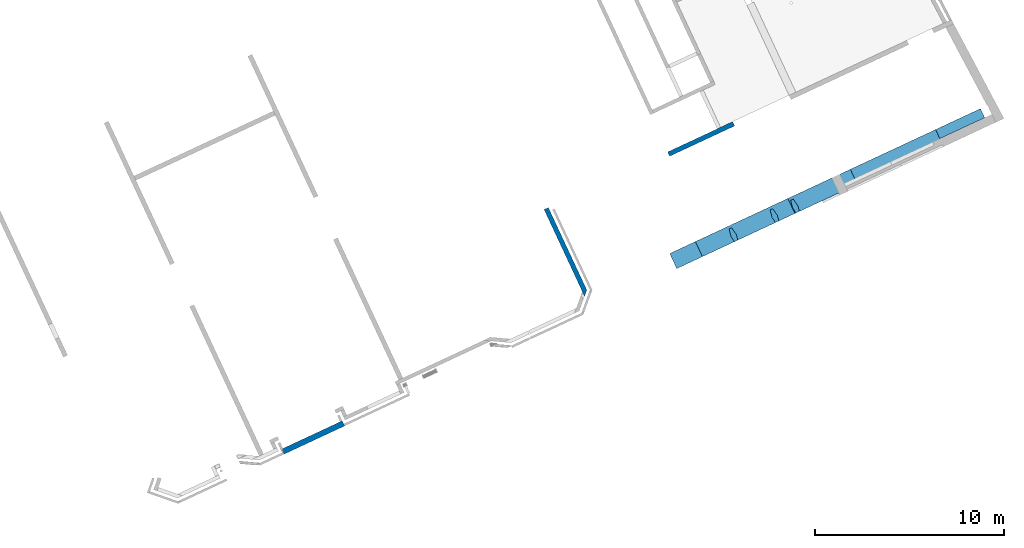
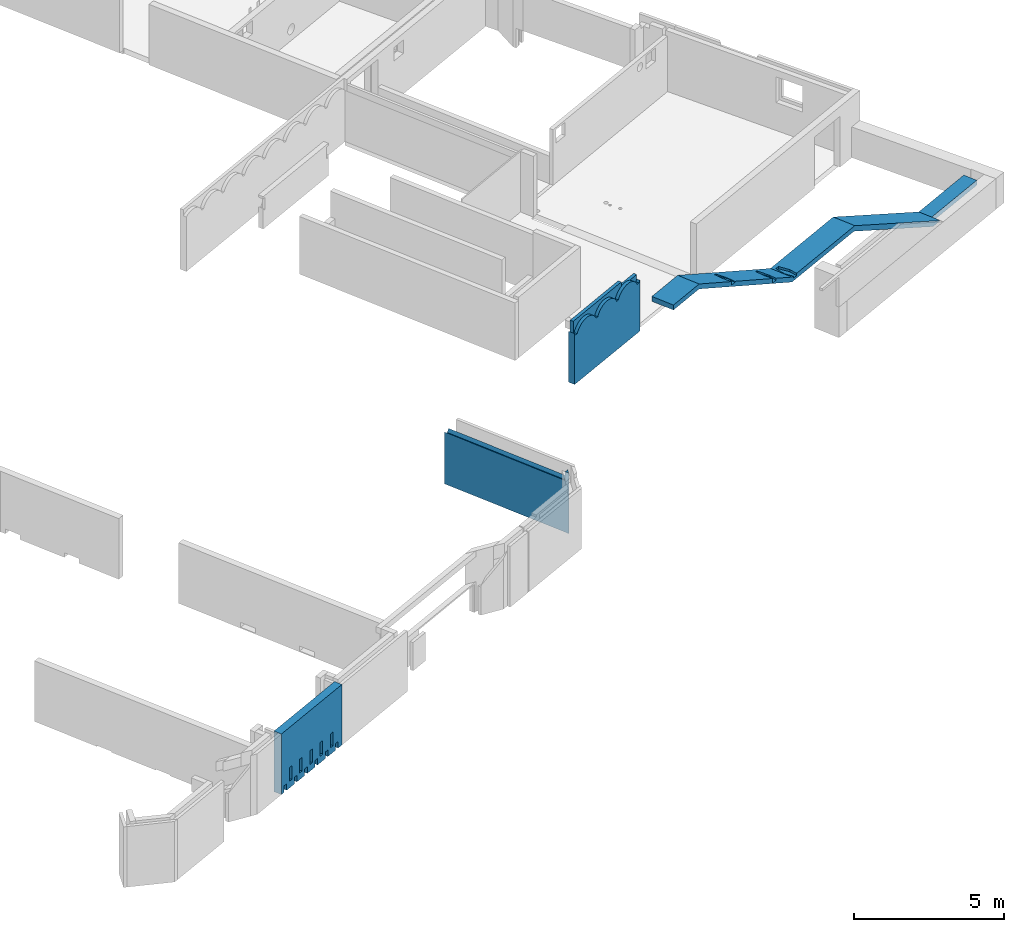
# One storey, part 6 of 13: 3 walls, 1 beam.
"""IFC2X3 building model written with IfcOpenShell, lengths in metres."""

from ifc_helpers import new_model, entity, si_unit, converted_unit, derived_unit, direction, frame, origin, place, context, subcontext, project, spatial, faceted_brep, material, layer, layer_set, type_object, element, save


model = new_model("IFC2X3")

# Units and contexts
model_context = context("Model", 3, precision=1e-05, world=origin(), true_north=direction((6.12303176911189e-17, 1.0)))
body_context = subcontext(model_context, "Body", "Model", "MODEL_VIEW")
ifc_project = project(units=[si_unit("LENGTHUNIT", "METRE"), si_unit("AREAUNIT", "SQUARE_METRE"), si_unit("VOLUMEUNIT", "CUBIC_METRE"), converted_unit("PLANEANGLEUNIT", "DEGREE", entity("IfcRatioMeasure", 0.0174532925199433), si_unit("PLANEANGLEUNIT", "RADIAN"), dimensions=[0, 0, 0, 0, 0, 0, 0]), si_unit("MASSUNIT", "GRAM", prefix="KILO"), derived_unit("MASSDENSITYUNIT", [(si_unit("MASSUNIT", "GRAM", prefix="KILO"), 1), (si_unit("LENGTHUNIT", "METRE"), -3)]), si_unit("TIMEUNIT", "SECOND"), si_unit("FREQUENCYUNIT", "HERTZ"), si_unit("THERMODYNAMICTEMPERATUREUNIT", "DEGREE_CELSIUS"), derived_unit("THERMALTRANSMITTANCEUNIT", [(si_unit("MASSUNIT", "GRAM", prefix="KILO"), 1), (si_unit("THERMODYNAMICTEMPERATUREUNIT", "KELVIN"), -1), (si_unit("TIMEUNIT", "SECOND"), -3)]), derived_unit("VOLUMETRICFLOWRATEUNIT", [(si_unit("LENGTHUNIT", "METRE"), 3), (si_unit("TIMEUNIT", "SECOND"), -1)]), si_unit("ELECTRICCURRENTUNIT", "AMPERE"), si_unit("ELECTRICVOLTAGEUNIT", "VOLT"), si_unit("POWERUNIT", "WATT"), si_unit("FORCEUNIT", "NEWTON", prefix="KILO"), si_unit("ILLUMINANCEUNIT", "LUX"), si_unit("LUMINOUSFLUXUNIT", "LUMEN"), si_unit("LUMINOUSINTENSITYUNIT", "CANDELA"), derived_unit("USERDEFINED", [(si_unit("MASSUNIT", "GRAM", prefix="KILO"), -1), (si_unit("LENGTHUNIT", "METRE"), -2), (si_unit("TIMEUNIT", "SECOND"), 3), (si_unit("LUMINOUSFLUXUNIT", "LUMEN"), 1)]), derived_unit("LINEARVELOCITYUNIT", [(si_unit("LENGTHUNIT", "METRE"), 1), (si_unit("TIMEUNIT", "SECOND"), -1)]), si_unit("PRESSUREUNIT", "PASCAL"), derived_unit("USERDEFINED", [(si_unit("LENGTHUNIT", "METRE"), -2), (si_unit("MASSUNIT", "GRAM", prefix="KILO"), 1), (si_unit("TIMEUNIT", "SECOND"), -2)])], contexts=[model_context])

# Site, building, storey
site_placement = place(None, frame((5.36960000000003, 43.3158000000006, 0.0), z_axis=(0.0, 0.0, 1.0), x_axis=(-0.422618261740703, 0.906307787036648, 0.0)))
site = spatial("IfcSite", under=ifc_project, at=site_placement, CompositionType="ELEMENT")
building_placement = place(site_placement, origin())
building = spatial("IfcBuilding", under=site, at=building_placement, CompositionType="ELEMENT")
storey_placement = place(building_placement, frame((0.0, 0.0, 2.56)))
storey = spatial("IfcBuildingStorey", under=building, at=storey_placement, CompositionType="ELEMENT", Elevation=2.56)

# Beam
ifc_material_1 = material(Name="BA")
beam_type = type_object("IfcBeamType", Name="SP_26_02_2:variable", PredefinedType="BEAM")
beam_placement = place(storey_placement, frame((0.120660848232912, 0.93585733205605, 1.04999999999999)))
element("IfcBeam", 1, at=beam_placement, inside=storey, type_object=beam_type, material=ifc_material_1, Name="SP_26_02_2:variable", ObjectType="SP_26_02_2:variable", context=body_context, shape_type="Brep", body=[
    faceted_brep([(0.880000000004672, 11.2638348482751, 2.85000000000001), (0.880000000004631, 7.60812275855246, 2.84999999999992), (0.880000000004576, 2.62419762538485, 0.200000000000014), (0.880000000004546, 0.0, 0.200000000000014), (0.880000000004546, 0.0, 0.0), (0.880000000004576, 2.67406322595346, 0.0), (0.880000000004632, 7.6579883591211, 2.64999999999992), (0.880000000004672, 11.2696234098998, 2.65000000000001), (0.880000000004732, 16.6754439072589, 5.47000000000002), (0.880000000004749, 18.1716685169687, 5.47000000000002), (0.880000000004749, 18.1716685169687, 5.67000000000001), (0.880000000004732, 16.6696553456341, 5.67000000000001), (0.0, 11.2638348482751, 2.85000000000001), (0.0, 11.192843488021, 2.85000000000001), (0.305008497369673, 11.2466685169686, 2.85000000000001), (0.730008497369677, 11.1716685169687, 2.85000000000001), (0.730008497369686, 11.0216685169687, 2.85), (0.305008497369691, 10.9466685169686, 2.85), (0.0, 11.0004935459162, 2.85), (0.0, 9.67058952069909, 2.84999999999997), (0.0, 7.60812275855247, 2.84999999999992), (0.0865825330115125, 7.60812275855247, 2.84999999999992), (0.52343446172795, 7.60812275855247, 2.84999999999992), (0.730000000004716, 2.62419762538485, 0.200000000000014), (0.350000000004517, 2.62419762538486, 0.200000000000014), (0.350000000004492, 0.0, 0.200000000000014), (0.350000000004492, 0.0, 0.0), (0.350000000004517, 2.67406322595347, 0.0), (0.350000000004512, 7.65798835912111, 2.64999999999992), (0.150000000004523, 7.65798835912111, 2.64999999999992), (0.0, 7.65798835912111, 2.64999999999992), (0.0, 11.2696234098998, 2.65000000000001), (0.150000000000136, 11.2696234098998, 2.65000000000001), (0.350000000000125, 11.2696234098998, 2.65000000000001), (0.350000000000216, 18.1716685169687, 5.67000000000001), (0.150000000000227, 18.1716685169687, 5.67000000000001), (0.0, 18.1716685169687, 5.67000000000001), (0.0, 16.6696553456342, 5.67000000000001), (0.350000000000216, 18.1716685169687, 5.47000000000002), (0.150000000000227, 18.1716685169687, 5.47000000000002), (0.0, 18.1716685169687, 5.47000000000002), (0.350000000000196, 16.6754439072589, 5.47000000000002), (0.150000000000207, 16.6754439072589, 5.47000000000002), (0.0, 16.6754439072589, 5.47000000000002), (0.350000000004521, 3.05020851902277, 0.200000000000014), (0.150000000004479, 3.05020851902277, 0.200000000000014), (0.0, 3.05020851902277, 0.200000000000014), (0.0, 7.48872297724012, 2.56000000000001), (0.0, 7.59284348802103, 2.61536185761163), (0.0, 2.62419762538486, 0.200000000000014), (0.0, 15.9853391629152, 5.11000000000001), (0.0, 15.9928434880211, 5.11391470578963), (0.261369741428162, 12.4389675600378, 3.26000000000001), (0.348647253311243, 12.4389675600378, 3.26000000000001), (0.305008497369684, 12.4466685169686, 3.26401728073577), (0.0, 14.7928434880211, 4.69094243768277), (0.305008497369708, 14.8466685169687, 4.71902079909088), (0.730008497369711, 14.7716685169687, 4.6798963035396), (0.730008497369721, 14.6216685169687, 4.60164731243702), (0.305008497369727, 14.5466685169686, 4.56252281688571), (0.0, 14.6004935459162, 4.5906011782938), (0.0, 12.3928434880211, 3.43895858004146), (0.305008497369684, 12.4466685169686, 3.46703694144957), (0.730008497369689, 12.3716685169687, 3.4279124458983), (0.730008497369698, 12.2216685169687, 3.34966345479572), (0.305008497369703, 12.1466685169686, 3.31053895924441), (0.0, 12.2004935459162, 3.3386173206525), (0.730008497369677, 11.1716685169687, 2.76000000000001), (0.350000000000124, 11.2387288400339, 2.76000000000001), (0.305008497369673, 11.2466685169686, 2.76000000000001), (0.150000000000136, 11.2193140762564, 2.76000000000001), (0.0, 11.192843488021, 2.76000000000001), (0.0, 11.0004935459162, 2.76000000000001), (0.150000000000133, 10.9740229576809, 2.76000000000001), (0.305008497369691, 10.9466685169686, 2.76000000000001), (0.350000000000121, 10.9546081939034, 2.76000000000001), (0.730008497369686, 11.0216685169687, 2.76000000000001), (0.730008497369712, 14.7716685169687, 4.54000000000001), (0.350000000000172, 14.8387288400339, 4.54000000000001), (0.305008497369707, 14.8466685169687, 4.54000000000001), (0.150000000000183, 14.8193140762564, 4.54000000000001), (0.0, 14.7928434880211, 4.54000000000001), (0.0, 14.6004935459162, 4.54000000000001), (0.15000000000018, 14.5740229576809, 4.54000000000001), (0.305008497369726, 14.5466685169687, 4.54000000000001), (0.350000000000168, 14.5546081939034, 4.54000000000001), (0.730008497369721, 14.6216685169687, 4.54000000000001), (0.730008497369698, 12.2216685169687, 3.26000000000001), (0.730008497369688, 12.3716685169687, 3.26000000000001), (0.35000000000014, 12.4387288400339, 3.26000000000001), (0.150000000000151, 12.4193140762564, 3.26000000000001), (0.0, 12.3928434880211, 3.26000000000001), (0.0, 12.2004935459162, 3.26000000000001), (0.150000000000148, 12.1740229576809, 3.26000000000001), (0.305008497369703, 12.1466685169686, 3.26000000000001), (0.350000000000137, 12.1546081939034, 3.26000000000001)], [[[0, 1, 2, 3, 4, 5, 6, 7, 8, 9, 10, 11]], [[1, 0, 12, 13, 14, 15, 16, 17, 18, 19, 20, 21, 22]], [[3, 2, 23, 24, 25]], [[4, 3, 25, 26]], [[5, 4, 26, 27]], [[7, 6, 28, 29, 30, 31, 32, 33]], [[11, 10, 34, 35, 36, 37]], [[10, 9, 38, 39, 40, 36, 35, 34]], [[9, 8, 41, 42, 43, 40, 39, 38]], [[6, 5, 27, 44, 45, 46, 47, 48, 30, 29, 28]], [[2, 1, 22, 21, 20, 49, 24, 23]], [[8, 7, 33, 32, 31, 50, 51, 43, 42, 41], [52, 53, 54]], [[0, 11, 37, 55, 56, 57, 58, 59, 60, 61, 62, 63, 64, 65, 66, 12]], [[67, 68, 69, 70, 71, 72, 73, 74, 75, 76]], [[69, 14, 13, 71, 70]], [[69, 68, 67, 15, 14]], [[67, 76, 16, 15]], [[76, 75, 74, 17, 16]], [[17, 74, 73, 72, 18]], [[25, 24, 44, 27, 26]], [[44, 24, 49, 46, 45]], [[77, 78, 79, 80, 81, 82, 83, 84, 85, 86]], [[79, 56, 55, 81, 80]], [[79, 78, 77, 57, 56]], [[77, 86, 58, 57]], [[86, 85, 84, 59, 58]], [[59, 84, 83, 82, 60]], [[87, 88, 89, 53, 52, 90, 91, 92, 93, 94, 95]], [[52, 54, 62, 61, 91, 90]], [[53, 89, 88, 63, 62, 54]], [[88, 87, 64, 63]], [[87, 95, 94, 65, 64]], [[65, 94, 93, 92, 66]], [[13, 12, 66, 92, 91, 61, 60, 82, 81, 55, 37, 36, 40, 43, 51, 50, 31, 30, 48, 47, 46, 49, 20, 19, 18, 72, 71]]]),
])

# Walls
ifc_material_2 = material(Name="C30/37 XS1")
ifc_layer_1 = layer(ifc_material_2, 0.25)
ifc_layer_set_1 = layer_set([ifc_layer_1])
wall_type_1 = type_object("IfcWallType", PredefinedType="STANDARD", material=ifc_layer_set_1)
wall_1_placement = place(storey_placement, frame((0.852418409073605, 24.032525849118, 0.0)))
element("IfcWall", 2, at=wall_1_placement, inside=storey, type_object=wall_type_1, context=body_context, shape_type="Brep", body=[
    faceted_brep([(0.249999999974401, -0.125000000000002, 0.0), (5.0782420595025, -0.124999999999998, 0.0), (5.0782420595025, -0.124999999999998, 2.11028845893373), (4.64468420774941, -0.124999999999998, 2.11028845893373), (3.87118159798596, -0.124999999999998, 2.11028845893373), (3.26765126049672, -0.124999999999998, 2.11028845893373), (2.66412102973845, -0.124999999999998, 2.11028845893373), (2.06059079898018, -0.124999999999993, 2.11028845893373), (1.45706046149094, -0.125000000000002, 2.11028845893373), (0.683557851727484, -0.125000000000002, 2.11028845893373), (0.249999999974401, -0.125000000000002, 2.11028845893373), (0.0, 0.125000000000002, 1.15), (0.0, 0.125000000000002, 1.92), (0.0, 0.125000000000002, 2.47), (0.148242059501641, 0.125000000000002, 2.47), (0.148242059501641, 0.125000000000002, 2.11028845916348), (0.581799363440353, 0.125000000000002, 2.11028845916348), (1.01535666737906, 0.125000000000002, 2.11028845916348), (1.88247349589419, 0.125000000000002, 2.11028845916348), (2.7495903244093, 0.124999999999998, 2.11028845916348), (3.61670493228673, 0.124999999999998, 2.11028845916348), (4.21112523098738, 0.125000000000002, 2.11028845916348), (4.64468253492609, 0.125000000000002, 2.11028845916348), (5.0782420595025, 0.125000000000002, 2.11028845916349), (5.0782420595025, 0.125000000000002, 0.0), (0.0, 0.125000000000002, 0.0), (5.0782420595025, 0.0825061092932384, 2.05241750578431), (5.0782420595025, 0.0470260731590913, 1.99000000000001), (5.0782420595025, -0.0470260733493381, 1.99000000000002), (5.0782420595025, -0.0825061094023481, 2.05241750565916), (0.14824205950164, -0.0232420595168198, 2.47), (0.172026073331723, -0.0470260733493381, 1.99000000000001), (0.14824205950164, -0.0232420595168198, 1.99000000000001), (0.207506109381106, -0.0825061094023568, 2.05241750565916), (1.38074272324429, 0.0470260731590913, 1.99000000000001), (1.99699305511561, 0.0470260731590913, 1.99000000000001), (1.76489184796493, 0.0810140177106562, 2.05010439938862), (1.19804994616677, 0.0825061092123612, 2.05241750565955), (0.677938003637152, 0.0825061092486633, 2.05241750571556), (4.54854611420273, 0.0825061092611985, 2.05241750573489), (4.02843417098123, 0.0825061092383674, 2.05241750569967), (2.30511705825131, 0.0856575443759862, 2.05722982574665), (1.01535782533669, 0.047026073159087, 1.99000000000001), (0.581798614934308, 0.0470260731590913, 1.99000000000001), (3.84574405072957, 0.0470260731590913, 1.99000000000001), (4.21112629366745, 0.0470260731590913, 1.99000000000001), (4.64468284910011, 0.0470260731590913, 1.99000000000001), (2.92136705850909, 0.0800733904828043, 2.04863445761746), (3.47007341872039, 0.0811502037255354, 2.05031646357054), (0.148242059501641, 0.0825104171612686, 2.05242415133289), (0.148242059501642, 0.0470260731590913, 1.99000000000001), (3.22949371885825, 0.0470260731590913, 1.99000000000001), (2.61324338698693, 0.0470260731590957, 1.99000000000001), (0.605583997985782, -0.0470260733493424, 1.99000000000001), (1.03914184041324, -0.0470260733493424, 1.99000000000001), (1.90625768972135, -0.0470260733493424, 1.99000000000001), (2.77337345680287, -0.0470260733493424, 1.99000000000001), (3.64048922388438, -0.0470260733493424, 1.99000000000001), (4.21112629242098, -0.0470260733493424, 1.99000000000001), (4.48419433102057, -0.0806888413936844, 2.0495972733865), (3.92580773121072, -0.0795937577060559, 2.04788138030582), (1.20488127663209, -0.0838609776227922, 2.05449843704673), (1.75882563069464, -0.0851135749870913, 2.05640613181807), (3.37540429262044, -0.0803239631703702, 2.04902692972282), (2.86818526471644, -0.0857028001815031, 2.05729822406117), (2.36235588561742, -0.0796140235231148, 2.04791324863953), (0.706122057160416, -0.0834928072503243, 2.053934777668)], [[[0, 1, 2, 3, 4, 5, 6, 7, 8, 9, 10]], [[11, 12, 13, 14, 15, 16, 17, 18, 19, 20, 21, 22, 23, 24, 25]], [[1, 24, 23, 26, 27, 28, 29, 2]], [[30, 14, 13]], [[31, 32, 30, 13, 12, 11, 25, 0, 10, 33]], [[34, 35, 36]], [[37, 18, 17, 16, 38]], [[39, 26, 23, 22, 21, 20, 40]], [[35, 41, 36]], [[42, 34, 37, 38, 43]], [[39, 40, 44, 45, 46, 27, 26]], [[20, 47, 48]], [[49, 16, 15]], [[49, 50, 43]], [[51, 47, 52]], [[41, 35, 52]], [[49, 43, 38]], [[47, 20, 19]], [[40, 48, 44]], [[18, 36, 41]], [[47, 41, 52]], [[19, 18, 41]], [[47, 51, 48]], [[41, 47, 19]], [[44, 48, 51]], [[40, 20, 48]], [[18, 37, 36]], [[34, 36, 37]], [[49, 38, 16]], [[27, 46, 45, 44, 51, 52, 35, 34, 42, 43, 50, 32, 31, 53, 54, 55, 56, 57, 58, 28]], [[28, 58, 59]], [[59, 60, 4]], [[3, 2, 29]], [[61, 62, 55]], [[4, 63, 5]], [[57, 60, 58]], [[60, 63, 4]], [[8, 62, 61]], [[63, 60, 57]], [[6, 64, 65]], [[10, 9, 66]], [[53, 33, 66]], [[58, 60, 59]], [[33, 10, 66]], [[59, 4, 3]], [[7, 6, 65]], [[64, 5, 63]], [[3, 29, 59]], [[28, 59, 29]], [[57, 56, 63]], [[56, 65, 64]], [[62, 8, 7]], [[56, 55, 65]], [[62, 65, 55]], [[65, 62, 7]], [[61, 55, 54]], [[53, 66, 54]], [[9, 8, 61]], [[33, 53, 31]], [[5, 64, 6]], [[56, 64, 63]], [[9, 61, 66]], [[66, 61, 54]], [[15, 14, 30, 32, 50, 49]], [[24, 1, 0, 25]]]),
])
ifc_layer_2 = layer(ifc_material_2, 0.3)
ifc_layer_set_2 = layer_set([ifc_layer_2])
wall_type_2 = type_object("IfcWallType", PredefinedType="NOTDEFINED", material=ifc_layer_set_2)
wall_2_placement = place(storey_placement, frame((0.150660848237833, 38.5875258490249, 0.0), z_axis=(0.0, 0.0, 1.0), x_axis=(0.0, 1.0, 0.0)))
element("IfcWall", 3, at=wall_2_placement, inside=storey, type_object=wall_type_2, Name="XS1", context=body_context, shape_type="Brep", body=[
    faceted_brep([(3.22000000000808, -0.15, 0.270000000000006), (3.37000000000716, -0.15, 0.270000000000006), (3.37000000000454, -0.15, 0.0), (3.52999999999997, -0.15, 0.0), (3.52999999999997, -0.15, 2.47), (3.46999999999998, -0.15, 2.47), (0.120000000000007, -0.15, 2.47), (0.059999999999969, -0.15, 2.47), (0.0, -0.15, 2.47), (0.0, -0.15, 0.0), (0.220000000006296, -0.15, 0.0), (0.220000000006296, -0.15, 0.269999999999999), (0.370000000006296, -0.15, 0.269999999999999), (0.370000000006296, -0.15, 0.0), (0.820000000006298, -0.15, 0.0), (0.820000000006298, -0.15, 0.269999999999997), (0.970000000006298, -0.15, 0.269999999999997), (0.970000000006298, -0.15, 0.0), (1.4200000000063, -0.15, 0.0), (1.4200000000063, -0.15, 0.270000000000013), (1.5700000000063, -0.15, 0.270000000000013), (1.5700000000063, -0.15, 0.0), (2.0200000000063, -0.15, 0.0), (2.0200000000063, -0.15, 0.270000000000011), (2.1700000000063, -0.15, 0.270000000000011), (2.1700000000063, -0.15, 0.0), (2.6200000000063, -0.15, 0.0), (2.6200000000063, -0.15, 0.270000000000008), (2.77000000000631, -0.15, 0.270000000000008), (2.77000000000631, -0.15, 0.0), (3.22000000000808, -0.15, 0.0), (2.92000000000631, -0.15, 0.830000000000006), (3.07000000000631, -0.15, 0.830000000000006), (3.07000000000631, -0.15, 0.270000000000007), (2.92000000000631, -0.15, 0.270000000000007), (2.3200000000063, -0.15, 0.830000000000008), (2.4700000000063, -0.15, 0.830000000000008), (2.4700000000063, -0.15, 0.27000000000001), (2.3200000000063, -0.15, 0.27000000000001), (1.7200000000063, -0.15, 0.830000000000012), (1.8700000000063, -0.15, 0.830000000000012), (1.8700000000063, -0.15, 0.270000000000012), (1.7200000000063, -0.15, 0.270000000000012), (1.1200000000063, -0.15, 0.829999999999995), (1.2700000000063, -0.15, 0.829999999999995), (1.2700000000063, -0.15, 0.269999999999995), (1.1200000000063, -0.15, 0.269999999999995), (0.520000000006297, -0.15, 0.829999999999998), (0.670000000006297, -0.15, 0.829999999999998), (0.670000000006297, -0.15, 0.269999999999998), (0.520000000006297, -0.15, 0.269999999999998), (3.37000000000715, 0.15, 0.270000000000006), (3.22000000000808, 0.15, 0.270000000000006), (3.22000000000808, 0.15, 0.0), (2.7700000000063, 0.15, 0.0), (2.7700000000063, 0.15, 0.270000000000008), (2.6200000000063, 0.15, 0.270000000000008), (2.6200000000063, 0.15, 0.0), (2.1700000000063, 0.15, 0.0), (2.1700000000063, 0.15, 0.270000000000011), (2.0200000000063, 0.15, 0.270000000000011), (2.0200000000063, 0.15, 0.0), (1.5700000000063, 0.15, 0.0), (1.5700000000063, 0.15, 0.270000000000013), (1.4200000000063, 0.15, 0.270000000000013), (1.4200000000063, 0.15, 0.0), (0.970000000006294, 0.15, 0.0), (0.970000000006294, 0.15, 0.269999999999997), (0.820000000006293, 0.15, 0.269999999999997), (0.820000000006293, 0.15, 0.0), (0.370000000006292, 0.15, 0.0), (0.370000000006292, 0.15, 0.269999999999999), (0.220000000006291, 0.15, 0.269999999999999), (0.220000000006291, 0.15, 0.0), (0.0, 0.15, 0.0), (0.0, 0.15, 2.47), (0.0600000000000037, 0.15, 2.47), (3.52999999999997, 0.15, 2.47), (3.52999999999997, 0.15, 0.0), (3.37000000000454, 0.15, 0.0), (3.0700000000063, 0.15, 0.830000000000006), (2.9200000000063, 0.15, 0.830000000000006), (2.9200000000063, 0.15, 0.270000000000007), (3.0700000000063, 0.15, 0.270000000000007), (2.4700000000063, 0.15, 0.830000000000008), (2.3200000000063, 0.15, 0.830000000000008), (2.3200000000063, 0.15, 0.27000000000001), (2.4700000000063, 0.15, 0.27000000000001), (1.8700000000063, 0.15, 0.830000000000012), (1.7200000000063, 0.15, 0.830000000000012), (1.7200000000063, 0.15, 0.270000000000012), (1.8700000000063, 0.15, 0.270000000000012), (1.2700000000063, 0.15, 0.829999999999995), (1.12000000000629, 0.15, 0.829999999999995), (1.12000000000629, 0.15, 0.269999999999995), (1.2700000000063, 0.15, 0.269999999999995), (0.670000000006293, 0.15, 0.829999999999998), (0.520000000006292, 0.15, 0.829999999999998), (0.520000000006292, 0.15, 0.269999999999998), (0.670000000006293, 0.15, 0.269999999999998), (3.52999999999997, 0.0300000000001498, 2.47), (0.0, 0.030000000000146, 2.47)], [[[0, 1, 2, 3, 4, 5, 6, 7, 8, 9, 10, 11, 12, 13, 14, 15, 16, 17, 18, 19, 20, 21, 22, 23, 24, 25, 26, 27, 28, 29, 30], [31, 32, 33, 34], [35, 36, 37, 38], [39, 40, 41, 42], [43, 44, 45, 46], [47, 48, 49, 50]], [[51, 52, 53, 54, 55, 56, 57, 58, 59, 60, 61, 62, 63, 64, 65, 66, 67, 68, 69, 70, 71, 72, 73, 74, 75, 76, 77, 78, 79], [80, 81, 82, 83], [84, 85, 86, 87], [88, 89, 90, 91], [92, 93, 94, 95], [96, 97, 98, 99]], [[1, 51, 79, 2]], [[1, 0, 52, 51]], [[77, 100, 4, 3, 78]], [[5, 4, 100, 77, 76, 75, 101, 8, 7, 6]], [[52, 0, 30, 53]], [[28, 27, 56, 55]], [[28, 55, 54, 29]], [[56, 27, 26, 57]], [[24, 23, 60, 59]], [[24, 59, 58, 25]], [[60, 23, 22, 61]], [[20, 19, 64, 63]], [[20, 63, 62, 21]], [[64, 19, 18, 65]], [[16, 15, 68, 67]], [[16, 67, 66, 17]], [[68, 15, 14, 69]], [[12, 11, 72, 71]], [[12, 71, 70, 13]], [[72, 11, 10, 73]], [[32, 31, 81, 80]], [[33, 32, 80, 83]], [[34, 33, 83, 82]], [[31, 34, 82, 81]], [[36, 35, 85, 84]], [[37, 36, 84, 87]], [[38, 37, 87, 86]], [[35, 38, 86, 85]], [[40, 39, 89, 88]], [[41, 40, 88, 91]], [[42, 41, 91, 90]], [[39, 42, 90, 89]], [[44, 43, 93, 92]], [[45, 44, 92, 95]], [[46, 45, 95, 94]], [[43, 46, 94, 93]], [[48, 47, 97, 96]], [[49, 48, 96, 99]], [[50, 49, 99, 98]], [[47, 50, 98, 97]], [[101, 75, 74, 9, 8]], [[10, 9, 74, 73]], [[14, 13, 70, 69]], [[18, 17, 66, 65]], [[22, 21, 62, 61]], [[26, 25, 58, 57]], [[30, 29, 54, 53]], [[3, 2, 79, 78]]]),
])
ifc_material_3 = material(Name="C30/37 XC1")
ifc_layer_3 = layer(ifc_material_3, 0.25)
ifc_layer_set_3 = layer_set([ifc_layer_3])
wall_type_3 = type_object("IfcWallType", PredefinedType="STANDARD", material=ifc_layer_set_3)
wall_3_placement = place(storey_placement, frame((5.8006587203224, 16.9325037603594, 0.0), z_axis=(0.0, 0.0, 1.0), x_axis=(0.0, -1.0, 0.0)))
element("IfcWall", 4, at=wall_3_placement, inside=storey, type_object=wall_type_3, context=body_context, shape_type="Brep", body=[
    faceted_brep([(3.51632678494477, 2.12791508525433e-06, 2.17191773820985), (3.56926670635075, 2.1279150845897e-06, 2.1170854495956), (3.61503925302638, 2.1279150849513e-06, 2.05614065784505), (3.65295183808113, 2.12791508525082e-06, 1.99000000000005), (3.74700398459011, 2.12791508491098e-06, 1.99000000000005), (3.77102251156613, 2.12791508510072e-06, 2.03403673484339), (3.79847781565814, 2.12791508423476e-06, 2.07588835932425), (3.79847781565814, 2.12791508423476e-06, 2.26), (3.39228155061049, 2.12791508535723e-06, 2.26), (3.4570302484893, 2.12791508478588e-06, 2.21979900280895), (1.98543635898921, 2.12791508832025e-06, 2.32772298895984), (2.06924586003783, 2.12791508789948e-06, 2.30998845551314), (2.14978928479854, 2.12791508745292e-06, 2.28081136055137), (2.22551252351945, 2.12791508696828e-06, 2.24075468495034), (2.29495447339686, 2.12791508751688e-06, 2.19059133438626), (2.35677523099588, 2.1279150869224e-06, 2.13128922588686), (2.4097819460927, 2.12791508734116e-06, 2.06399261157949), (2.45295183808057, 2.12791508659934e-06, 1.99000000000004), (2.54700398458956, 2.12791508734236e-06, 1.99000000000004), (2.58717803299033, 2.12791508657688e-06, 2.05955017085772), (2.63604824121633, 2.12791508696296e-06, 2.12328705456896), (2.69278662113085, 2.12791508632833e-06, 2.18013196387302), (2.75643015493181, 2.12791508683112e-06, 2.22912059181799), (2.82589922012527, 2.12791508629707e-06, 2.26942251434201), (2.90000000000025, 2.12791508579961e-06, 2.30034933877814), (2.90000000000025, 2.12791508688248e-06, 2.47), (0.100000000000601, 2.12791509183381e-06, 2.47), (0.0999779113353591, 2.12791509075076e-06, 1.99000000000004), (0.147003984589842, 2.12791509112228e-06, 1.99000000000004), (0.19017387657771, 2.12791509146332e-06, 2.06399261157948), (0.243180591674532, 2.12791509079922e-06, 2.13128922588686), (0.305001349273552, 2.12791509128761e-06, 2.19059133438625), (0.374443299150957, 2.12791509075334e-06, 2.24075468495033), (0.450166537871875, 2.1279150902687e-06, 2.28081136055136), (0.530709962632577, 2.127915090905e-06, 2.30998845551313), (0.614519463681198, 2.12791509048424e-06, 2.32772298895984), (0.699977911335628, 2.1279150900765e-06, 2.33367276770246), (0.785436358990057, 2.12791508966877e-06, 2.32772298895984), (0.869245860038678, 2.12791509033087e-06, 2.30998845551313), (0.949789284799381, 2.12791508988431e-06, 2.28081136055137), (1.0255125235203, 2.12791508939967e-06, 2.24075468495034), (1.09495447339771, 2.12791508994827e-06, 2.19059133438626), (1.15677523099673, 2.12791508935379e-06, 2.13128922588686), (1.20978194609355, 2.12791508977255e-06, 2.06399261157949), (1.25295183808142, 2.12791508903073e-06, 1.99000000000004), (1.347003984589, 2.12791508869089e-06, 1.99000000000004), (1.39017387657687, 2.12791508903193e-06, 2.06399261157949), (1.44318059167369, 2.12791508836783e-06, 2.13128922588686), (1.50500134927271, 2.12791508885622e-06, 2.19059133438626), (1.57444329915011, 2.12791508832195e-06, 2.24075468495034), (1.65016653787103, 2.12791508892017e-06, 2.28081136055137), (1.73070996263173, 2.12791508847361e-06, 2.30998845551313), (1.81451946368035, 2.12791508805285e-06, 2.32772298895984), (1.89997791133478, 2.12791508764511e-06, 2.33367276770246), (0.0, -0.125, 0.0), (3.79847781565814, -0.125000000000001, 0.0), (3.79847781565814, -0.125000000000001, 2.07588835932425), (3.77099486003994, -0.125000000000001, 2.03399060053965), (3.74700398459011, -0.125, 1.99000000000005), (3.65295183808112, -0.125000000000001, 1.99000000000004), (3.60978194609325, -0.125, 2.06399261157949), (3.55677523099643, -0.125, 2.13128922588686), (3.49495447339741, -0.125, 2.19059133438626), (3.42551252352001, -0.125, 2.24075468495034), (3.34978928479909, -0.125, 2.28081136055137), (3.26924586003839, -0.125, 2.30998845551314), (3.18543635898977, -0.125, 2.32772298895985), (3.09997791133534, -0.125000000000001, 2.33367276770246), (3.01451946368091, -0.125, 2.32772298895985), (2.93070996263229, -0.125, 2.30998845551314), (2.85016653787158, -0.125000000000001, 2.28081136055137), (2.77444329915066, -0.125, 2.24075468495034), (2.70500134927326, -0.125000000000001, 2.19059133438626), (2.64318059167424, -0.125, 2.13128922588687), (2.59017387657742, -0.125, 2.06399261157949), (2.54700398458956, -0.125000000000001, 1.99000000000004), (2.45295183808056, -0.125, 1.99000000000004), (2.40978194609269, -0.125000000000001, 2.06399261157949), (2.35677523099587, -0.125, 2.13128922588686), (2.29495447339685, -0.125000000000001, 2.19059133438626), (2.22551252351945, -0.125, 2.24075468495034), (2.14978928479853, -0.125000000000001, 2.28081136055137), (2.06924586003783, -0.125, 2.30998845551313), (1.98543635898921, -0.125, 2.32772298895984), (1.89997791133478, -0.125, 2.33367276770246), (1.81451946368035, -0.125, 2.32772298895984), (1.73070996263173, -0.125000000000001, 2.30998845551314), (1.65016653787102, -0.125, 2.28081136055137), (1.57444329915011, -0.125, 2.24075468495034), (1.5050013492727, -0.125, 2.19059133438626), (1.44318059167368, -0.125000000000001, 2.13128922588686), (1.39017387657686, -0.125, 2.06399261157949), (1.347003984589, -0.125000000000001, 1.99000000000004), (1.25295183808141, -0.125, 1.99000000000004), (1.20978194609354, -0.125000000000001, 2.06399261157948), (1.15677523099672, -0.125, 2.13128922588686), (1.0949544733977, -0.125, 2.19059133438625), (1.02551252352029, -0.125, 2.24075468495033), (0.949789284799374, -0.125, 2.28081136055136), (0.869245860038672, -0.125, 2.30998845551313), (0.785436358990051, -0.125000000000001, 2.32772298895984), (0.699977911335621, -0.125, 2.33367276770246), (0.614519463681192, -0.125, 2.32772298895984), (0.530709962632571, -0.125, 2.30998845551313), (0.450166537871868, -0.125, 2.28081136055137), (0.374443299150951, -0.125000000000001, 2.24075468495034), (0.305001349273546, -0.125, 2.19059133438626), (0.243180591674523, -0.125000000000001, 2.13128922588686), (0.190173876577704, -0.125, 2.06399261157949), (0.147003984589845, -0.125, 1.99000000000004), (0.0529518380814108, -0.125, 1.99000000000003), (0.0283089752590706, -0.125, 2.03507596722363), (0.0, -0.125, 2.07794455046364), (2.90000000000025, 0.125, 2.26), (3.79847781565814, 0.125, 2.26), (3.79847781565814, 0.125, 0.0), (0.0, 0.125, 0.0), (0.0, 0.125, 2.07794455046363), (0.0283089752590727, 0.125, 2.03507596722363), (0.0529518380814194, 0.125000000000001, 1.99000000000004), (0.100000000000601, 0.125, 1.99000000000004), (0.100000000000597, 0.125, 2.47), (2.90000000000025, 0.125, 2.47), (2.98175296310535, 2.12791495108708e-06, 2.32223463069527), (3.06573239247254, 2.12791495066766e-06, 2.3327212136431), (3.15035674910354, 2.1279149513362e-06, 2.33161159949846), (3.23403234843505, 2.12791495091438e-06, 2.31892668502211), (3.3151833733349, 2.12791495047262e-06, 2.29490535832134), (2.90000000000025, 2.12791495152408e-06, 2.26)], [[[0, 1, 2, 3, 4, 5, 6, 7, 8, 9]], [[10, 11, 12, 13, 14, 15, 16, 17, 18, 19, 20, 21, 22, 23, 24, 25, 26, 27, 28, 29, 30, 31, 32, 33, 34, 35, 36, 37, 38, 39, 40, 41, 42, 43, 44, 45, 46, 47, 48, 49, 50, 51, 52, 53]], [[54, 55, 56, 57, 58, 59, 60, 61, 62, 63, 64, 65, 66, 67, 68, 69, 70, 71, 72, 73, 74, 75, 76, 77, 78, 79, 80, 81, 82, 83, 84, 85, 86, 87, 88, 89, 90, 91, 92, 93, 94, 95, 96, 97, 98, 99, 100, 101, 102, 103, 104, 105, 106, 107, 108, 109, 110, 111, 112]], [[113, 114, 115, 116, 117, 118, 119, 120, 121, 122]], [[55, 115, 114, 7, 6, 56]], [[26, 25, 122, 121]], [[54, 112, 117, 116]], [[27, 26, 121]], [[121, 120, 27]], [[117, 112, 111, 118]], [[111, 110, 119, 118]], [[119, 110, 109, 28, 27, 120]], [[45, 44, 93, 92]], [[18, 17, 76, 75]], [[4, 3, 59, 58]], [[31, 30, 107, 106]], [[107, 30, 29, 108]], [[105, 32, 31, 106]], [[103, 34, 33, 104]], [[34, 103, 102, 35]], [[33, 32, 105, 104]], [[101, 36, 35, 102]], [[108, 29, 28, 109]], [[37, 100, 99, 38]], [[38, 99, 98, 39]], [[97, 40, 39, 98]], [[41, 96, 95, 42]], [[95, 94, 43, 42]], [[96, 41, 40, 97]], [[43, 94, 93, 44]], [[37, 36, 101, 100]], [[48, 47, 90, 89]], [[90, 47, 46, 91]], [[88, 49, 48, 89]], [[86, 51, 50, 87]], [[51, 86, 85, 52]], [[50, 49, 88, 87]], [[84, 53, 52, 85]], [[91, 46, 45, 92]], [[10, 83, 82, 11]], [[11, 82, 81, 12]], [[80, 13, 12, 81]], [[14, 79, 78, 15]], [[78, 77, 16, 15]], [[79, 14, 13, 80]], [[16, 77, 76, 17]], [[10, 53, 84, 83]], [[20, 74, 73]], [[74, 19, 75]], [[72, 21, 73]], [[23, 71, 70]], [[24, 70, 69]], [[71, 22, 72]], [[123, 69, 68]], [[21, 20, 73]], [[19, 18, 75]], [[20, 19, 74]], [[23, 22, 71]], [[123, 24, 69]], [[124, 123, 68]], [[23, 70, 24]], [[21, 72, 22]], [[68, 67, 124]], [[125, 67, 66]], [[126, 66, 65]], [[64, 127, 65]], [[9, 63, 62]], [[61, 60, 1]], [[61, 0, 62]], [[8, 64, 63]], [[2, 60, 59]], [[126, 125, 66]], [[8, 127, 64]], [[126, 65, 127]], [[0, 9, 62]], [[2, 1, 60]], [[3, 2, 59]], [[0, 61, 1]], [[8, 63, 9]], [[67, 125, 124]], [[4, 58, 57]], [[4, 57, 5]], [[5, 56, 6]], [[56, 5, 57]], [[8, 7, 114, 113, 128]], [[128, 24, 123, 124, 125, 126, 127, 8]], [[24, 128, 113, 122, 25]], [[116, 115, 55, 54]]]),
])

save(model, "model.ifc")
